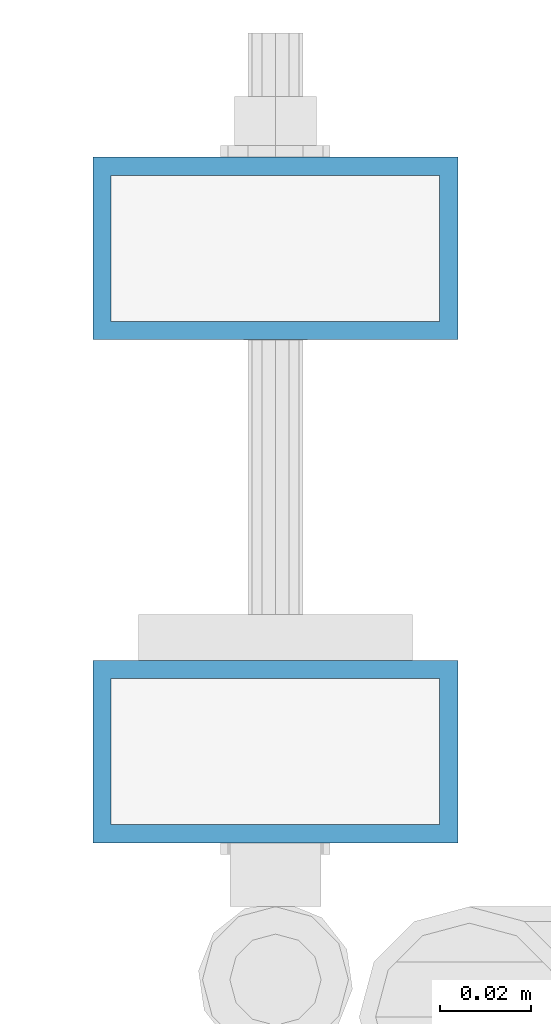
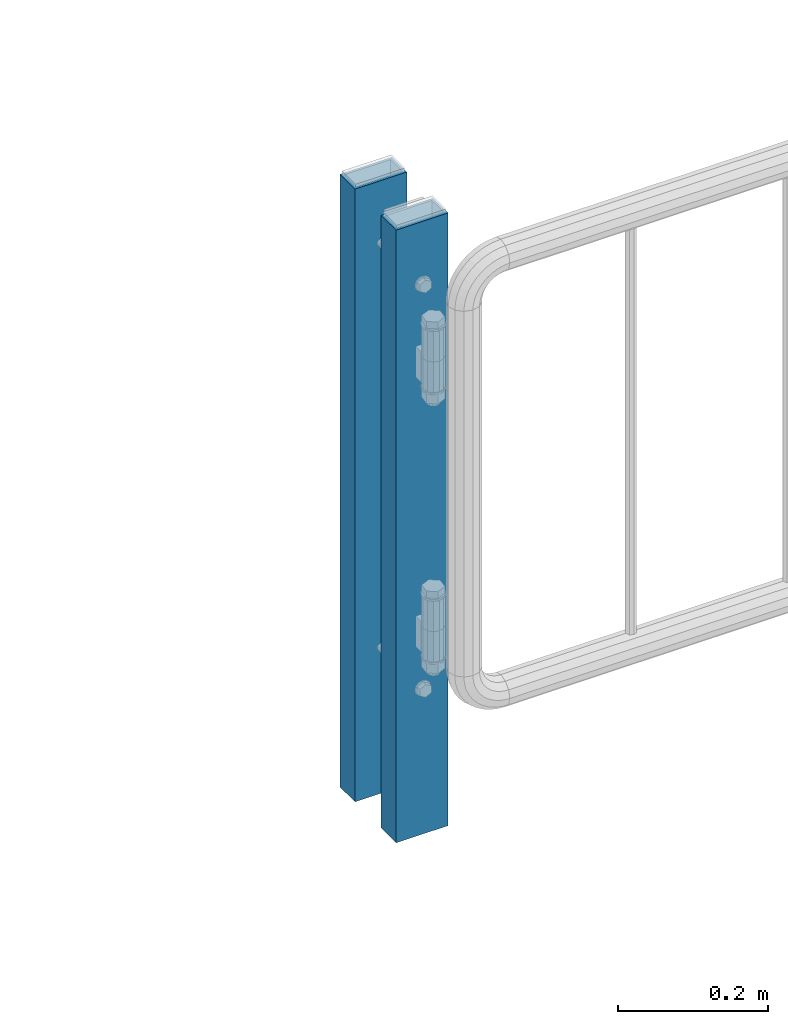
# One storey, part 64 of 270: 2 columns.
"""IFC2X3 building model written with IfcOpenShell, lengths in millimetres."""

from ifc_helpers import new_model, si_unit, frame, origin_with_axes, place, context, subcontext, project, spatial, faceted_brep, material, type_object, element, save


model = new_model("IFC2X3")

# Units and contexts
model_context = context("Model", 3, precision=1e-05, world=origin_with_axes())
body_context = subcontext(model_context, "Body", "Model", "MODEL_VIEW")
ifc_project = project(units=[si_unit("LENGTHUNIT", "METRE", prefix="MILLI"), si_unit("AREAUNIT", "SQUARE_METRE"), si_unit("VOLUMEUNIT", "CUBIC_METRE"), si_unit("MASSUNIT", "GRAM", prefix="KILO"), si_unit("TIMEUNIT", "SECOND"), si_unit("PLANEANGLEUNIT", "RADIAN"), si_unit("SOLIDANGLEUNIT", "STERADIAN"), si_unit("THERMODYNAMICTEMPERATUREUNIT", "DEGREE_CELSIUS"), si_unit("LUMINOUSINTENSITYUNIT", "LUMEN")], contexts=[model_context])

# Site, building, storey
site_placement = place(None, origin_with_axes())
site = spatial("IfcSite", under=ifc_project, at=site_placement, CompositionType="ELEMENT")
building_placement = place(site_placement, origin_with_axes())
building = spatial("IfcBuilding", under=site, at=building_placement, Name="Standard", CompositionType="ELEMENT")
storey_placement = place(building_placement, origin_with_axes())
storey = spatial("IfcBuildingStorey", under=building, at=storey_placement, Name="Undefined", CompositionType="ELEMENT", Elevation=0.0)

# Columns
ifc_material = material()
column_type = type_object("IfcColumnType", PredefinedType="NOTDEFINED")
for number, where, z_axis, x_axis in (
    (1, (30428.7460172356, -17889.6960000038, 6.54446186132418e-06), (-1.0, 0.0, 0.0), (0.0, 0.0, 1.0)),
    (2, (30428.7460172356, -17999.9960000038, 6.54446186132418e-06), (-1.0, 0.0, 0.0), (0.0, 0.0, 1.0)),
):
    element("IfcColumn", number, at=place(storey_placement, frame(where, z_axis=z_axis, x_axis=x_axis)), inside=storey, type_object=column_type, material=ifc_material, context=body_context, shape_type="Brep", body=[
        faceted_brep([(0.0, 16.0, -36.0), (0.0, -16.0, -36.0), (1000.0, -16.0, -36.0), (1000.0, 16.0, -36.0), (0.0, -16.0, 36.0), (1000.0, -16.0, 36.0), (0.0, 16.0, 36.0), (1000.0, 16.0, 36.0), (0.0, 20.0, -40.0), (0.0, 20.0, 40.0), (1000.0, 20.0, 40.0), (1000.0, 20.0, -40.0), (0.0, -20.0, 40.0), (1000.0, -20.0, 40.0), (0.0, -20.0, -40.0), (1000.0, -20.0, -40.0)], [[[0, 1, 2, 3]], [[1, 4, 5, 2]], [[4, 6, 7, 5]], [[6, 0, 3, 7]], [[8, 9, 10, 11]], [[9, 12, 13, 10]], [[12, 14, 15, 13]], [[14, 8, 11, 15]], [[13, 15, 11, 10], [5, 7, 3, 2]], [[14, 12, 9, 8], [6, 4, 1, 0]]]),
    ])

save(model, "model.ifc")
